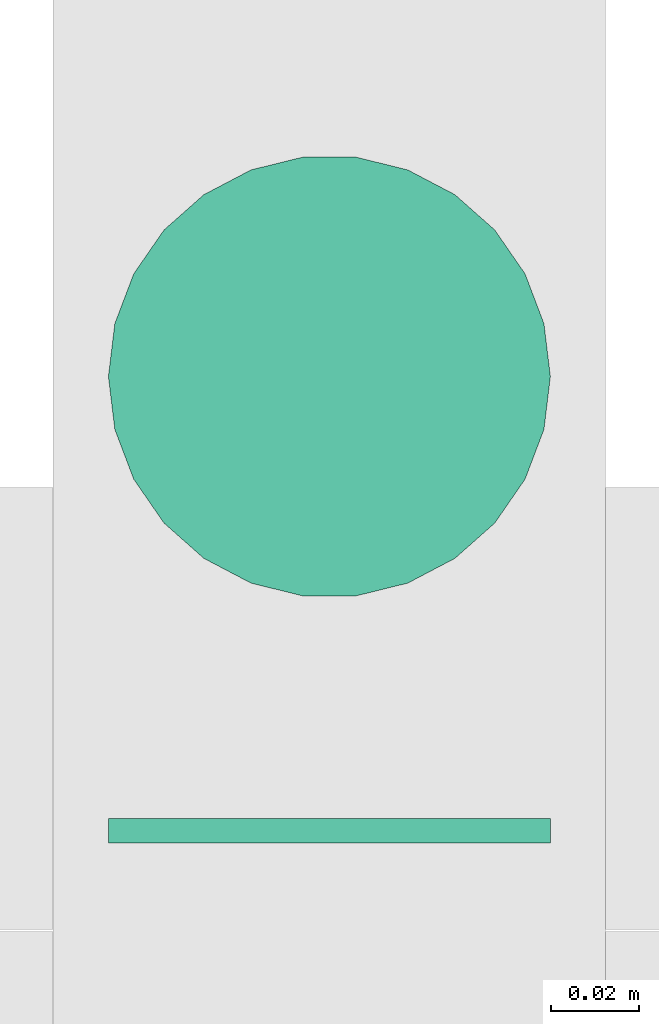
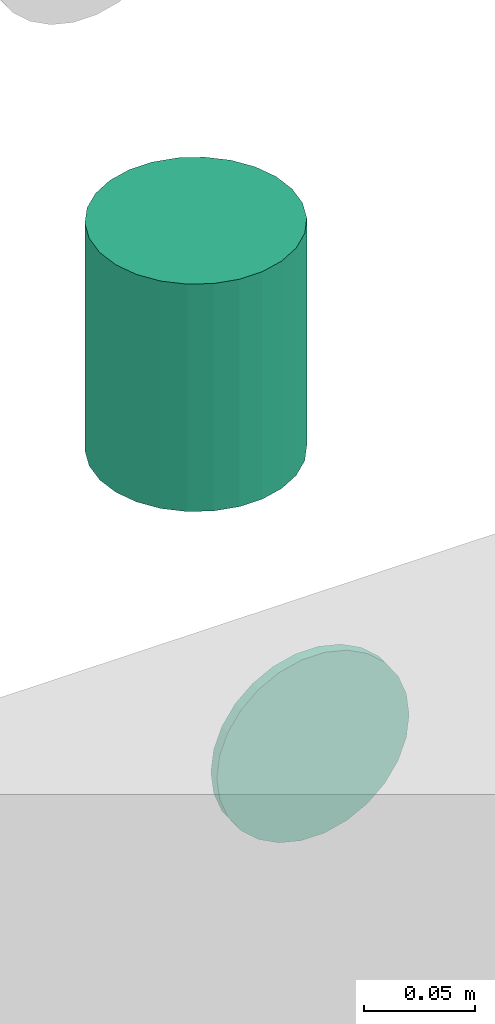
# One storey, part 155 of 337: 2 flow segments.
"""IFC2X3 building model written with IfcOpenShell, lengths in millimetres."""

from ifc_helpers import new_model, entity, si_unit, converted_unit, derived_unit, direction, frame, origin, origin_2d_with_axis, place, context, subcontext, project, spatial, circle, extrude, type_object, element, save


model = new_model("IFC2X3")

# Units and contexts
model_context = context("Model", 3, precision=0.01, world=origin(), true_north=direction((6.12303176911189e-17, 1.0)))
body_context = subcontext(model_context, "Body", "Model", "MODEL_VIEW")
ifc_project = project(units=[si_unit("LENGTHUNIT", "METRE", prefix="MILLI"), si_unit("AREAUNIT", "SQUARE_METRE"), si_unit("VOLUMEUNIT", "CUBIC_METRE"), converted_unit("PLANEANGLEUNIT", "DEGREE", entity("IfcRatioMeasure", 0.0174532925199433), si_unit("PLANEANGLEUNIT", "RADIAN"), dimensions=[0, 0, 0, 0, 0, 0, 0]), si_unit("MASSUNIT", "GRAM", prefix="KILO"), derived_unit("MASSDENSITYUNIT", [(si_unit("MASSUNIT", "GRAM", prefix="KILO"), 1), (si_unit("LENGTHUNIT", "METRE"), -3)]), derived_unit("MOMENTOFINERTIAUNIT", [(si_unit("LENGTHUNIT", "METRE"), 4)]), si_unit("TIMEUNIT", "SECOND"), si_unit("FREQUENCYUNIT", "HERTZ"), si_unit("THERMODYNAMICTEMPERATUREUNIT", "DEGREE_CELSIUS"), derived_unit("THERMALTRANSMITTANCEUNIT", [(si_unit("MASSUNIT", "GRAM", prefix="KILO"), 1), (si_unit("THERMODYNAMICTEMPERATUREUNIT", "KELVIN"), -1), (si_unit("TIMEUNIT", "SECOND"), -3)]), derived_unit("VOLUMETRICFLOWRATEUNIT", [(si_unit("LENGTHUNIT", "METRE"), 3), (si_unit("TIMEUNIT", "SECOND"), -1)]), derived_unit("MASSFLOWRATEUNIT", [(si_unit("MASSUNIT", "GRAM", prefix="KILO"), 1), (si_unit("TIMEUNIT", "SECOND"), -1)]), derived_unit("ROTATIONALFREQUENCYUNIT", [(si_unit("TIMEUNIT", "SECOND"), -1)]), si_unit("ELECTRICCURRENTUNIT", "AMPERE"), si_unit("ELECTRICVOLTAGEUNIT", "VOLT"), si_unit("POWERUNIT", "WATT"), si_unit("FORCEUNIT", "NEWTON", prefix="KILO"), si_unit("ILLUMINANCEUNIT", "LUX"), si_unit("LUMINOUSFLUXUNIT", "LUMEN"), si_unit("LUMINOUSINTENSITYUNIT", "CANDELA"), derived_unit("USERDEFINED", [(si_unit("MASSUNIT", "GRAM", prefix="KILO"), -1), (si_unit("LENGTHUNIT", "METRE"), -2), (si_unit("TIMEUNIT", "SECOND"), 3), (si_unit("LUMINOUSFLUXUNIT", "LUMEN"), 1)]), derived_unit("LINEARVELOCITYUNIT", [(si_unit("LENGTHUNIT", "METRE"), 1), (si_unit("TIMEUNIT", "SECOND"), -1)]), si_unit("PRESSUREUNIT", "PASCAL"), derived_unit("USERDEFINED", [(si_unit("LENGTHUNIT", "METRE"), -2), (si_unit("MASSUNIT", "GRAM", prefix="KILO"), 1), (si_unit("TIMEUNIT", "SECOND"), -2)]), derived_unit("LINEARFORCEUNIT", [(si_unit("MASSUNIT", "GRAM", prefix="KILO"), 1), (si_unit("LENGTHUNIT", "METRE"), 1), (si_unit("TIMEUNIT", "SECOND"), -2), (si_unit("LENGTHUNIT", "METRE"), -1)]), derived_unit("PLANARFORCEUNIT", [(si_unit("MASSUNIT", "GRAM", prefix="KILO"), 1), (si_unit("LENGTHUNIT", "METRE"), 1), (si_unit("TIMEUNIT", "SECOND"), -2), (si_unit("LENGTHUNIT", "METRE"), -2)])], contexts=[model_context])

# Site, building, storey
site_placement = place(None, origin())
site = spatial("IfcSite", under=ifc_project, at=site_placement, CompositionType="ELEMENT")
building_placement = place(site_placement, origin())
building = spatial("IfcBuilding", under=site, at=building_placement, CompositionType="ELEMENT")
storey_placement = place(building_placement, origin())
storey = spatial("IfcBuildingStorey", under=building, at=storey_placement, CompositionType="ELEMENT", Elevation=0.0)

# Flow segments
duct_segment_type = type_object("IfcDuctSegmentType", PredefinedType="NOTDEFINED")
flow_segment_1_placement = place(storey_placement, frame((33910.91, 16220.0, 14923.4)))
element("IfcFlowSegment", 1, at=flow_segment_1_placement, inside=storey, type_object=duct_segment_type, context=body_context, shape_type="SweptSolid", body=[
    extrude(circle(Radius=50.0, at=origin_2d_with_axis()), frame((51.6, 0.0, 51.6), z_axis=(0.0, 1.0, 0.0), x_axis=(1.0, 0.0, 0.0)), (0.0, 0.0, 1.0), 5.50051730127168),
])
flow_segment_2_placement = place(storey_placement, frame((33910.91, 16273.91, 15075.0)))
element("IfcFlowSegment", 2, at=flow_segment_2_placement, inside=storey, type_object=duct_segment_type, context=body_context, shape_type="SweptSolid", body=[
    extrude(circle(Radius=50.0, at=origin_2d_with_axis()), frame((51.6, 51.6, 0.0)), (0.0, 0.0, 1.0), 125.000000000032),
])

save(model, "model.ifc")
